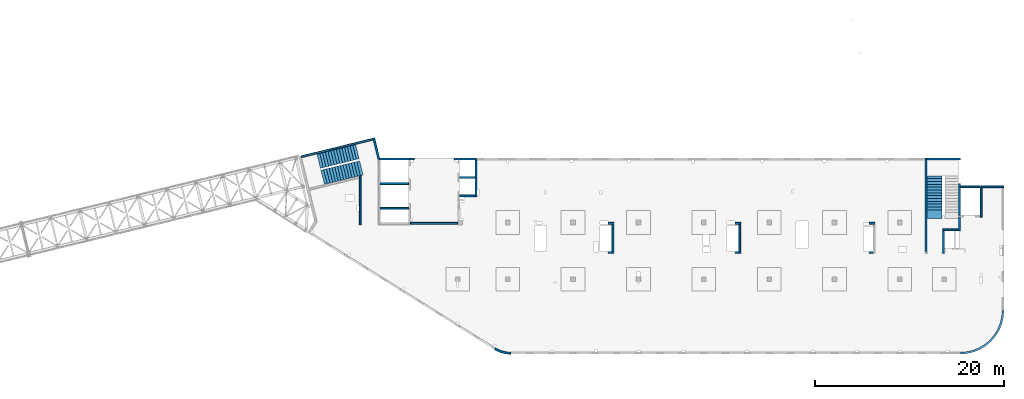
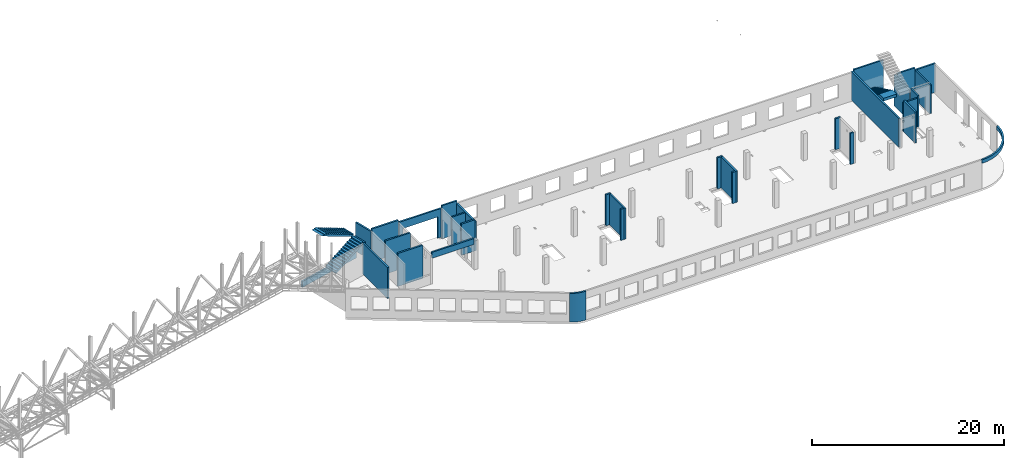
# One storey, part 21 of 92: 31 walls, 3 stairs, 1 opening.
"""IFC4 building model written with IfcOpenShell, lengths in millimetres."""

from ifc_helpers import new_model, entity, si_unit, converted_unit, derived_unit, direction, frame, origin, place, context, subcontext, project, spatial, indexed_curve, outline, extrude, polygons, material, type_object, element, save


model = new_model("IFC4")

# Units and contexts
model_context = context("Model", 3, precision=0.01, world=origin(), true_north=direction((6.12303176911189e-17, 1.0)))
plan_context = context("Plan", 3, precision=0.01, world=origin(), true_north=direction((6.12303176911189e-17, 1.0)))
body_context = subcontext(model_context, "Body", "Model", "MODEL_VIEW")
ifc_project = project(units=[si_unit("LENGTHUNIT", "METRE", prefix="MILLI"), si_unit("AREAUNIT", "SQUARE_METRE"), si_unit("VOLUMEUNIT", "CUBIC_METRE"), converted_unit("PLANEANGLEUNIT", "DEGREE", entity("IfcRatioMeasure", 0.0174532925199433), si_unit("PLANEANGLEUNIT", "RADIAN"), dimensions=[0, 0, 0, 0, 0, 0, 0]), si_unit("MASSUNIT", "GRAM", prefix="KILO"), derived_unit("MASSDENSITYUNIT", [(si_unit("MASSUNIT", "GRAM", prefix="KILO"), 1), (si_unit("LENGTHUNIT", "METRE"), -3)]), derived_unit("MOMENTOFINERTIAUNIT", [(si_unit("LENGTHUNIT", "METRE"), 4)]), si_unit("TIMEUNIT", "SECOND"), si_unit("FREQUENCYUNIT", "HERTZ"), si_unit("THERMODYNAMICTEMPERATUREUNIT", "DEGREE_CELSIUS"), derived_unit("THERMALTRANSMITTANCEUNIT", [(si_unit("MASSUNIT", "GRAM", prefix="KILO"), 1), (si_unit("THERMODYNAMICTEMPERATUREUNIT", "KELVIN"), -1), (si_unit("TIMEUNIT", "SECOND"), -3)]), derived_unit("VOLUMETRICFLOWRATEUNIT", [(si_unit("LENGTHUNIT", "METRE"), 3), (si_unit("TIMEUNIT", "SECOND"), -1)]), derived_unit("MASSFLOWRATEUNIT", [(si_unit("MASSUNIT", "GRAM", prefix="KILO"), 1), (si_unit("TIMEUNIT", "SECOND"), -1)]), derived_unit("ROTATIONALFREQUENCYUNIT", [(si_unit("TIMEUNIT", "SECOND"), -1)]), si_unit("ELECTRICCURRENTUNIT", "AMPERE"), si_unit("ELECTRICVOLTAGEUNIT", "VOLT"), si_unit("POWERUNIT", "WATT"), si_unit("FORCEUNIT", "NEWTON", prefix="KILO"), si_unit("ILLUMINANCEUNIT", "LUX"), si_unit("LUMINOUSFLUXUNIT", "LUMEN"), si_unit("LUMINOUSINTENSITYUNIT", "CANDELA"), derived_unit("USERDEFINED", [(si_unit("MASSUNIT", "GRAM", prefix="KILO"), -1), (si_unit("LENGTHUNIT", "METRE"), -2), (si_unit("TIMEUNIT", "SECOND"), 3), (si_unit("LUMINOUSFLUXUNIT", "LUMEN"), 1)]), derived_unit("LINEARVELOCITYUNIT", [(si_unit("LENGTHUNIT", "METRE"), 1), (si_unit("TIMEUNIT", "SECOND"), -1)]), si_unit("PRESSUREUNIT", "PASCAL"), derived_unit("USERDEFINED", [(si_unit("LENGTHUNIT", "METRE"), -2), (si_unit("MASSUNIT", "GRAM", prefix="KILO"), 1), (si_unit("TIMEUNIT", "SECOND"), -2)]), derived_unit("LINEARFORCEUNIT", [(si_unit("MASSUNIT", "GRAM", prefix="KILO"), 1), (si_unit("LENGTHUNIT", "METRE"), 1), (si_unit("TIMEUNIT", "SECOND"), -2), (si_unit("LENGTHUNIT", "METRE"), -1)]), derived_unit("PLANARFORCEUNIT", [(si_unit("MASSUNIT", "GRAM", prefix="KILO"), 1), (si_unit("LENGTHUNIT", "METRE"), 1), (si_unit("TIMEUNIT", "SECOND"), -2), (si_unit("LENGTHUNIT", "METRE"), -2)])], contexts=[model_context, plan_context])

# Site, building, storey
site_placement = place(None, origin())
site = spatial("IfcSite", under=ifc_project, at=site_placement, CompositionType="ELEMENT")
building_placement = place(site_placement, origin())
building = spatial("IfcBuilding", under=site, at=building_placement, CompositionType="ELEMENT")
storey_placement = place(building_placement, frame((0.0, 0.0, 15900.0)))
storey = spatial("IfcBuildingStorey", under=building, at=storey_placement, Name="05", CompositionType="ELEMENT", Elevation=15900.0)

# Walls
ifc_material_1 = material()
wall_type = type_object("IfcWallType", Name=":ADSK_ 25_200", PredefinedType="STANDARD")
wall_1_placement = place(storey_placement, frame((71070.0, 17470.0, -150.0)))
element("IfcWall", 1, at=wall_1_placement, inside=storey, type_object=wall_type, material=ifc_material_1, Name=":ADSK_ 25_200", ObjectType=":ADSK_ 25_200", PredefinedType="NOTDEFINED", context=body_context, shape_type="SweptSolid", body=[
    extrude(outline(indexed_curve([(2500.00000000001, -99.9999999999999), (2500.00000000001, 100.0), (99.9999999999943, 99.9999999999992), (99.9999999999949, -100.000000000001), (199.999999999998, -100.0), (2300.00000000001, -100.0), (2500.00000000001, -99.9999999999999)], self_intersect=False)), origin(), (0.0, 0.0, 1.0), 3650.0),
])
wall_2_placement = place(storey_placement, frame((71170.0, 17370.0, -150.0), z_axis=(0.0, 0.0, 1.0), x_axis=(0.0, -1.0, 0.0)))
element("IfcWall", 2, at=wall_2_placement, inside=storey, type_object=wall_type, material=ifc_material_1, Name=":ADSK_ 25_200", ObjectType=":ADSK_ 25_200", PredefinedType="NOTDEFINED", context=body_context, shape_type="SweptSolid", body=[
    extrude(outline(indexed_curve([(3100.0, 100.000000000003), (-2.79449581754433e-13, 100.000000000003), (2.79449581754433e-13, -100.000000000003), (3100.0, -100.000000000003), (3100.0, 100.000000000003)], self_intersect=False)), origin(), (0.0, 0.0, 1.0), 3650.0),
])
wall_3_placement = place(storey_placement, frame((68870.0, 14270.0, -150.0), z_axis=(0.0, 0.0, 1.0), x_axis=(0.0, -1.0, 0.0)))
element("IfcWall", 3, at=wall_3_placement, inside=storey, type_object=wall_type, material=ifc_material_1, Name=":ADSK_ 25_200", ObjectType=":ADSK_ 25_200", PredefinedType="NOTDEFINED", context=body_context, shape_type="SweptSolid", body=[
    extrude(outline(indexed_curve([(1439.99999999999, 100.000000000003), (0.0, 100.000000000003), (0.0, -100.000000000003), (1439.99999999999, -100.000000000003), (1439.99999999999, 100.000000000003)], self_intersect=False)), origin(), (0.0, 0.0, 1.0), 3950.0),
])
wall_4_placement = place(storey_placement, frame((68770.0, 12930.0, -150.0), z_axis=(0.0, 0.0, 1.0), x_axis=(-1.0, 0.0, 0.0)))
element("IfcWall", 4, at=wall_4_placement, inside=storey, type_object=wall_type, material=ifc_material_1, Name=":ADSK_ 25_200", ObjectType=":ADSK_ 25_200", PredefinedType="NOTDEFINED", context=body_context, shape_type="SweptSolid", body=[
    extrude(outline(indexed_curve([(1689.99999999997, 99.9999999999989), (-3.84449868389964e-13, 99.9999999999989), (3.84449868389964e-13, -99.9999999999989), (1689.99999999997, -99.9999999999989), (1689.99999999997, 99.9999999999989)], self_intersect=False)), origin(), (0.0, 0.0, 1.0), 3650.0),
])
wall_5_placement = place(storey_placement, frame((67180.0, 12830.0, -150.0), z_axis=(0.0, 0.0, 1.0), x_axis=(0.0, -1.0, 0.0)))
element("IfcWall", 5, at=wall_5_placement, inside=storey, type_object=wall_type, material=ifc_material_1, Name=":ADSK_ 25_200", ObjectType=":ADSK_ 25_200", PredefinedType="NOTDEFINED", context=body_context, shape_type="SweptSolid", body=[
    extrude(outline(indexed_curve([(2404.99999999995, 100.000000000003), (0.0, 100.000000000003), (0.0, -100.000000000003), (2404.99999999995, -100.000000000003), (2404.99999999995, 100.000000000003)], self_intersect=False)), origin(), (0.0, 0.0, 1.0), 3950.0),
])
wall_6_placement = place(storey_placement, frame((65330.0, 10625.0, -150.0), z_axis=(0.0, 0.0, 1.0), x_axis=(0.0, 1.0, 0.0)))
element("IfcWall", 6, at=wall_6_placement, inside=storey, type_object=wall_type, material=ifc_material_1, Name=":ADSK_ 25_200", ObjectType=":ADSK_ 25_200", PredefinedType="NOTDEFINED", context=body_context, shape_type="SweptSolid", body=[
    extrude(outline(indexed_curve([(9875.00063936713, 100.000000000003), (-1.71685740578866e-13, 100.000000000003), (1.71685740578866e-13, -100.000000000003), (9875.00063936713, -100.000000000004), (9875.00063936713, 100.000000000003)], self_intersect=False)), origin(), (0.0, 0.0, 1.0), 3650.0),
])
wall_7_placement = place(storey_placement, frame((68970.0, -100.0, 3050.0)))
element("IfcWall", 7, at=wall_7_placement, inside=storey, type_object=wall_type, material=ifc_material_1, Name=":ADSK_ 25_200", ObjectType=":ADSK_ 25_200", PredefinedType="NOTDEFINED", context=body_context, shape_type="SweptSolid", body=[
    extrude(outline(indexed_curve([(4399.99918212903, 4499.99918212888), (4345.82789081698, 3811.68766389508), (4184.64789385715, 3140.32465961517), (3920.42797770043, 2502.44135458057), (3559.67411357824, 1913.74455277455), (3111.26925889869, 1388.72992323025), (2586.25462935438, 940.325068550716), (1997.55782754836, 579.571204428538), (1359.67452251375, 315.351288271842), (688.311518233829, 154.171291312031), (3.46517481375486e-11, 100.0), (0.0, -100.0), (719.598411241839, -43.3663768070014), (1421.47792138871, 125.139985012801), (2088.35592749623, 401.369899590849), (2703.81167981284, 778.521669675706), (3252.69061513597, 1247.30856699292), (3721.47751245321, 1796.18750231603), (4098.6292825381, 2411.64325463263), (4374.85919711618, 3078.52126074015), (4543.365558936, 3780.40077088701), (4599.99918212903, 4499.99918212885), (4399.99918212903, 4499.99918212888)], self_intersect=False)), origin(), (0.0, 0.0, 1.0), 450.000000000002),
])
wall_8_placement = place(storey_placement, frame((19822.35, 371.16, -150.0)))
element("IfcWall", 8, at=wall_8_placement, inside=storey, type_object=wall_type, material=ifc_material_1, Name=":ADSK_ 25_200", ObjectType=":ADSK_ 25_200", PredefinedType="NOTDEFINED", context=body_context, shape_type="SweptSolid", body=[
    extrude(outline(indexed_curve([(1647.48298908956, -371.159642137684), (1479.53495854193, -366.732336838998), (1312.09852486252, -352.905454552832), (1145.69934172072, -329.72240370142), (980.859806418502, -297.255965670987), (818.09741986465, -255.608066320247), (657.923161920899, -204.909455992096), (500.839887220395, -145.319299033065), (347.340746494629, -77.024674109233), (197.907638365059, -0.239986887291593), (53.0096964598414, 84.7937030753815), (-53.0096964598197, -84.7937030753918), (101.553010904459, -175.499182842681), (260.953382356765, -257.405447245706), (424.69099282044, -330.255357933605), (592.251800794088, -393.820208274097), (763.109762144871, -447.900441360165), (936.728481583211, -492.326276503471), (1112.5628966341, -526.958242247616), (1290.06098881835, -551.687614227945), (1468.66551667174, -566.436756503237), (1647.81576516126, -571.159365287708), (1647.48298908956, -371.159642137684)], self_intersect=False)), origin(), (0.0, 0.0, 1.0), 3650.0),
])
wall_9_placement = place(storey_placement, frame((17825.0, 20300.0, -150.0), z_axis=(0.0, 0.0, 1.0), x_axis=(0.0, -1.0, 0.0)))
element("IfcWall", 9, at=wall_9_placement, inside=storey, type_object=wall_type, material=ifc_material_1, Name=":ADSK_ 25_200", ObjectType=":ADSK_ 25_200", PredefinedType="NOTDEFINED", context=body_context, shape_type="SweptSolid", body=[
    extrude(outline(indexed_curve([(3900.00063936684, 99.9999999999989), (-1.66594915657375e-13, 99.9999999999989), (1.66594915657375e-13, -99.9999999999989), (3900.00063936684, -99.9999999999989), (3900.00063936684, 99.9999999999989)], self_intersect=False)), origin(), (0.0, 0.0, 1.0), 3650.0),
])
wall_10_placement = place(storey_placement, frame((17725.0, 16500.0, -150.0), z_axis=(0.0, 0.0, 1.0), x_axis=(-1.0, 0.0, 0.0)))
element("IfcWall", 10, at=wall_10_placement, inside=storey, type_object=wall_type, material=ifc_material_1, Name=":ADSK_ 25_200", ObjectType=":ADSK_ 25_200", PredefinedType="NOTDEFINED", context=body_context, shape_type="SweptSolid", body=[
    extrude(outline(indexed_curve([(1624.99999999999, 99.9999999999982), (-3.56011111002209e-13, 99.9999999999989), (3.56011111002209e-13, -99.9999999999989), (1624.99999999999, -99.9999999999996), (1624.99999999999, 99.9999999999982)], self_intersect=False)), origin(), (0.0, 0.0, 1.0), 3950.0),
])
wall_11_placement = place(storey_placement, frame((5600.0, 13450.0, -150.0), z_axis=(0.0, 0.0, 1.0), x_axis=(0.0, 1.0, 0.0)))
element("IfcWall", 11, at=wall_11_placement, inside=storey, type_object=wall_type, material=ifc_material_1, Name=":ADSK_ 25_200", ObjectType=":ADSK_ 25_200", PredefinedType="NOTDEFINED", context=body_context, shape_type="SweptSolid", body=[
    extrude(outline(indexed_curve([(5191.05764338749, -100.0), (5142.30552742916, 99.9999999999995), (4936.44934265344, 100.0), (-1.37676332088153e-13, 100.0), (1.37676332088153e-13, -100.0), (5191.05764338749, -100.0)], self_intersect=False)), origin(), (0.0, 0.0, 1.0), 3950.0),
])

# Wall, opening
wall_12_placement = place(storey_placement, frame((10900.0, 20400.0, -150.0)))
wall_12 = element("IfcWall", 12, at=wall_12_placement, inside=storey, type_object=wall_type, material=ifc_material_1, Name=":ADSK_ 25_200", ObjectType=":ADSK_ 25_200", PredefinedType="NOTDEFINED", context=body_context, shape_type="Tessellation", body=[
    polygons([(5000.0, -100.000000000003, 3650.0), (-4.99784381508401e-13, -100.000000000003, 3650.0), (-4.99784381508401e-13, -100.000000000003, -2.16573425859679e-12), (399.999999999991, -99.9999999999989, -2.16573425859679e-12), (399.999999999993, -100.000000000003, 2699.99999999805), (4599.99999999999, -100.000000000003, 2699.99999999804), (4599.99999999999, -100.000000000003, -2.16573425859679e-12), (5000.0, -100.000000000003, -2.16573425859679e-12), (-1.16616415338434e-12, 99.9999999999989, 3650.0), (5000.0, 99.9999999999989, 3650.0), (5000.0, 99.9999999999989, 49.9999999999973), (5000.0, 99.9999999999989, -2.16573425859679e-12), (4599.99999999999, 99.9999999999989, -2.16573425859679e-12), (4599.99999999999, 99.9999999999989, 2699.99999999804), (399.999999999992, 100.000000000003, 2699.99999999805), (399.999999999992, 100.000000000003, -2.16573425859679e-12), (-1.16616415338434e-12, 99.9999999999989, -2.16573425859679e-12), (-1.16616415338434e-12, 99.9999999999989, 49.9999999999973)], [[[1, 2, 3, 4, 5, 6, 7, 8]], [[9, 10, 11, 12, 13, 14, 15, 16, 17, 18]], [[3, 17, 16, 4]], [[2, 1, 10, 9]], [[5, 15, 14, 6]], [[6, 14, 13, 7]], [[15, 5, 4, 16]], [[8, 12, 11, 10, 1]], [[17, 3, 2, 9, 18]], [[12, 8, 7, 13]]], closed=True),
])
opening_placement = place(wall_12_placement, frame((-10900.0, -20400.0, 150.0)))
element("IfcOpeningElement", 13, at=opening_placement, cuts=wall_12, Name=":ADSK_ 25_200", PredefinedType="OPENING", context=body_context, shape_type="SweptSolid", body=[
    extrude(outline(indexed_curve([(-2100.0, -1349.99999999902), (2100.0, -1349.99999999902), (2100.0, 1349.99999999902), (-2100.0, 1349.99999999902), (-2100.0, -1349.99999999902)], self_intersect=False)), frame((13400.0, 20200.0, 1200.0), z_axis=(0.0, 1.0, 0.0), x_axis=(1.0, 0.0, 0.0)), (0.0, 0.0, 1.0), 400.000000001945),
])

# Walls
wall_13_placement = place(storey_placement, frame((68870.0, 17780.0, -400.0), z_axis=(0.0, 0.0, 1.0), x_axis=(0.0, -1.0, 0.0)))
element("IfcWall", 14, at=wall_13_placement, inside=storey, type_object=wall_type, material=ifc_material_1, Name=":ADSK_ 25_200", ObjectType=":ADSK_ 25_200", PredefinedType="NOTDEFINED", context=body_context, shape_type="Tessellation", body=[
    polygons([(2.16573425859679e-12, -99.9999999999946, 0.0), (3310.0, -99.9999999999946, 0.0), (3310.0, -99.9999999999946, 299.999999999997), (3310.0, -99.9999999999946, 3900.0), (2.16573425859679e-12, -99.9999999999946, 3900.0), (3310.0, 100.000000000012, 0.0), (410.0, 100.000000000003, 0.0), (210.0, 100.000000000003, 0.0), (2.16573425859679e-12, 100.000000000012, 0.0), (2.16573425859679e-12, 100.000000000012, 3900.0), (3310.0, 100.000000000012, 3900.0)], [[[1, 2, 3, 4, 5]], [[6, 7, 8, 9, 10, 11]], [[2, 1, 9, 8, 7, 6]], [[9, 1, 5, 10]], [[2, 6, 11, 4, 3]], [[5, 4, 11, 10]]], closed=True),
])
wall_14_placement = place(storey_placement, frame((68970.0, 17470.0, -100.0)))
element("IfcWall", 15, at=wall_14_placement, inside=storey, type_object=wall_type, material=ifc_material_1, Name=":ADSK_ 25_200", ObjectType=":ADSK_ 25_200", PredefinedType="NOTDEFINED", context=body_context, shape_type="Tessellation", body=[
    polygons([(2099.99918212888, -100.000000000001, 2.16573425859679e-12), (2099.99918212888, -100.000000000001, 3600.0), (2099.99918212888, -100.000000000001, 3850.0), (2099.99918212888, -100.000000000001, 3900.0), (6.89939203009021e-12, -100.000000000001, 3900.0), (6.89939203009021e-12, -100.000000000001, 2.16573425859679e-12), (6.28061057235613e-12, 99.9999999999989, 3900.0), (2099.99918212888, 99.9999999999989, 3900.0), (2099.99918212888, 99.9999999999989, 3850.0), (2099.99918212888, 99.9999999999989, 3600.0), (2099.99918212888, 99.9999999999989, 2.16573425859679e-12), (6.28061057235613e-12, 99.9999999999989, 2.16573425859679e-12)], [[[1, 2, 3, 4, 5, 6]], [[7, 8, 9, 10, 11, 12]], [[5, 4, 8, 7]], [[5, 7, 12, 6]], [[1, 11, 10, 9, 8, 4, 3, 2]], [[1, 6, 12, 11]]], closed=True),
])
wall_15_placement = place(storey_placement, frame((65430.0, 20400.0, -400.0)))
element("IfcWall", 16, at=wall_15_placement, inside=storey, type_object=wall_type, material=ifc_material_1, Name=":ADSK_ 25_200", ObjectType=":ADSK_ 25_200", PredefinedType="NOTDEFINED", context=body_context, shape_type="SweptSolid", body=[
    extrude(outline(indexed_curve([(3539.99999999995, 99.9999999999989), (-3.67073603151997e-13, 99.9999999999989), (3.67073603151997e-13, -99.9999999999989), (3539.99999999995, -99.9999999999989), (3539.99999999995, 99.9999999999989)], self_intersect=False)), origin(), (0.0, 0.0, 1.0), 4150.0),
])
wall_16_placement = place(storey_placement, frame((16000.0, 20400.0, -400.0)))
element("IfcWall", 17, at=wall_16_placement, inside=storey, type_object=wall_type, material=ifc_material_1, Name=":ADSK_ 25_200", ObjectType=":ADSK_ 25_200", PredefinedType="NOTDEFINED", context=body_context, shape_type="SweptSolid", body=[
    extrude(outline(indexed_curve([(1824.99999999999, -100.000000000003), (1824.99999999999, 99.9999999999995), (1724.99999999999, 99.9999999999992), (99.9999999999987, 99.9999999999992), (-2.66551908750372e-13, 99.9999999999989), (2.66551908750383e-13, -100.000000000003), (1724.99999999999, -100.000000000003), (1824.99999999999, -100.000000000003)], self_intersect=False)), origin(), (0.0, 0.0, 1.0), 4200.0),
])
wall_17_placement = place(storey_placement, frame((16100.0, 18450.0, -400.0)))
element("IfcWall", 18, at=wall_17_placement, inside=storey, type_object=wall_type, material=ifc_material_1, Name=":ADSK_ 25_200", ObjectType=":ADSK_ 25_200", PredefinedType="NOTDEFINED", context=body_context, shape_type="SweptSolid", body=[
    extrude(outline(indexed_curve([(1624.99999999999, 99.9999999999989), (-2.66551908750371e-13, 99.9999999999989), (2.66551908750371e-13, -99.9999999999989), (1624.99999999999, -99.9999999999989), (1624.99999999999, 99.9999999999989)], self_intersect=False)), origin(), (0.0, 0.0, 1.0), 3900.0),
])
wall_18_placement = place(storey_placement, frame((7600.0, 20400.0, -400.0)))
element("IfcWall", 19, at=wall_18_placement, inside=storey, type_object=wall_type, material=ifc_material_1, Name=":ADSK_ 25_200", ObjectType=":ADSK_ 25_200", PredefinedType="NOTDEFINED", context=body_context, shape_type="SweptSolid", body=[
    extrude(outline(indexed_curve([(3200.0, -100.000000000003), (3200.0, 99.9999999999995), (3100.0, 99.9999999999992), (7.9410256148549e-13, 99.9999999999989), (2.88764567812915e-13, -100.000000000003), (3200.0, -100.000000000003)], self_intersect=False)), origin(), (0.0, 0.0, 1.0), 4200.0),
])
for number, where, name in (
    (20, (7700.0, 17800.0, -400.0), ":ADSK_ 25_200"),
    (21, (7700.0, 15200.0, -400.0), ":ADSK_ 25_200"),
):
    element("IfcWall", number, at=place(storey_placement, frame(where)), inside=storey, type_object=wall_type, material=ifc_material_1, Name=name, ObjectType=":ADSK_ 25_200", PredefinedType="NOTDEFINED", context=body_context, shape_type="SweptSolid", body=[
        extrude(outline(indexed_curve([(3000.0, 99.9999999999989), (-2.88764567812902e-13, 99.9999999999989), (2.88764567812902e-13, -99.9999999999989), (3000.0, -99.9999999999989), (3000.0, 99.9999999999989)], self_intersect=False)), origin(), (0.0, 0.0, 1.0), 4200.0),
    ])
wall_19_placement = place(storey_placement, frame((59330.0, 13600.0, -150.0)))
element("IfcWall", 22, at=wall_19_placement, inside=storey, type_object=wall_type, material=ifc_material_1, Name=":ADSK_ 25_200", ObjectType=":ADSK_ 25_200", PredefinedType="NOTDEFINED", context=body_context, shape_type="SweptSolid", body=[
    extrude(outline(indexed_curve([(599.999999999993, 99.9999999999989), (-3.60955709766131e-13, 99.9999999999989), (3.60955709766131e-13, -99.9999999999989), (599.999999999994, -99.9999999999989), (599.999999999993, 99.9999999999989)], self_intersect=False)), origin(), (0.0, 0.0, 1.0), 3950.0),
])
wall_20_placement = place(storey_placement, frame((59730.0, 10525.0, -150.0), z_axis=(0.0, 0.0, 1.0), x_axis=(-1.0, 0.0, 0.0)))
element("IfcWall", 23, at=wall_20_placement, inside=storey, type_object=wall_type, material=ifc_material_1, Name=":ADSK_ 25_200", ObjectType=":ADSK_ 25_200", PredefinedType="NOTDEFINED", context=body_context, shape_type="SweptSolid", body=[
    extrude(outline(indexed_curve([(399.999999999987, 99.9999999999982), (-3.60955709766136e-13, 99.9999999999989), (3.60955709766136e-13, -99.9999999999989), (399.999999999987, -99.9999999999996), (399.999999999987, 99.9999999999982)], self_intersect=False)), origin(), (0.0, 0.0, 1.0), 3950.0),
])
wall_21_placement = place(storey_placement, frame((45170.0, 13600.0, -150.0)))
element("IfcWall", 24, at=wall_21_placement, inside=storey, type_object=wall_type, material=ifc_material_1, Name=":ADSK_ 25_200", ObjectType=":ADSK_ 25_200", PredefinedType="NOTDEFINED", context=body_context, shape_type="SweptSolid", body=[
    extrude(outline(indexed_curve([(599.999999999993, 99.9999999999989), (-3.60955709766131e-13, 99.9999999999989), (3.60955709766131e-13, -99.9999999999989), (599.999999999994, -99.9999999999989), (599.999999999993, 99.9999999999989)], self_intersect=False)), origin(), (0.0, 0.0, 1.0), 3950.0),
])
wall_22_placement = place(storey_placement, frame((45670.0, 13500.0, -150.0), z_axis=(0.0, 0.0, 1.0), x_axis=(0.0, -1.0, 0.0)))
element("IfcWall", 25, at=wall_22_placement, inside=storey, type_object=wall_type, material=ifc_material_1, Name=":ADSK_ 25_200", ObjectType=":ADSK_ 25_200", PredefinedType="NOTDEFINED", context=body_context, shape_type="SweptSolid", body=[
    extrude(outline(indexed_curve([(3074.99985044015, 100.000000000003), (-2.64517173435081e-13, 100.000000000003), (2.64517173435081e-13, -100.000000000003), (3074.99985044015, -100.000000000004), (3074.99985044015, 100.000000000003)], self_intersect=False)), origin(), (0.0, 0.0, 1.0), 3950.0),
])
wall_23_placement = place(storey_placement, frame((45570.0, 10525.0, -150.0), z_axis=(0.0, 0.0, 1.0), x_axis=(-1.0, 0.0, 0.0)))
element("IfcWall", 26, at=wall_23_placement, inside=storey, type_object=wall_type, material=ifc_material_1, Name=":ADSK_ 25_200", ObjectType=":ADSK_ 25_200", PredefinedType="NOTDEFINED", context=body_context, shape_type="SweptSolid", body=[
    extrude(outline(indexed_curve([(399.999999999995, 99.9999999999982), (-3.60955709766131e-13, 99.9999999999989), (3.60955709766131e-13, -99.9999999999989), (399.999999999996, -99.9999999999996), (399.999999999995, 99.9999999999982)], self_intersect=False)), origin(), (0.0, 0.0, 1.0), 3950.0),
])
wall_24_placement = place(storey_placement, frame((31770.0, 13600.0, -150.0)))
element("IfcWall", 27, at=wall_24_placement, inside=storey, type_object=wall_type, material=ifc_material_1, Name=":ADSK_ 25_200", ObjectType=":ADSK_ 25_200", PredefinedType="NOTDEFINED", context=body_context, shape_type="SweptSolid", body=[
    extrude(outline(indexed_curve([(600.000000000002, 99.9999999999989), (-3.60955709766126e-13, 99.9999999999989), (3.60955709766126e-13, -99.9999999999989), (600.000000000003, -99.9999999999989), (600.000000000002, 99.9999999999989)], self_intersect=False)), origin(), (0.0, 0.0, 1.0), 3950.0),
])
wall_25_placement = place(storey_placement, frame((32270.0, 13500.0, -150.0), z_axis=(0.0, 0.0, 1.0), x_axis=(0.0, -1.0, 0.0)))
element("IfcWall", 28, at=wall_25_placement, inside=storey, type_object=wall_type, material=ifc_material_1, Name=":ADSK_ 25_200", ObjectType=":ADSK_ 25_200", PredefinedType="NOTDEFINED", context=body_context, shape_type="SweptSolid", body=[
    extrude(outline(indexed_curve([(3074.99985044025, 99.9999999999987), (-1.32258586717531e-13, 99.9999999999989), (1.32258586717531e-13, -99.9999999999989), (3074.99985044025, -99.9999999999992), (3074.99985044025, 99.9999999999987)], self_intersect=False)), origin(), (0.0, 0.0, 1.0), 3950.0),
])
wall_26_placement = place(storey_placement, frame((32170.0, 10525.0, -150.0), z_axis=(0.0, 0.0, 1.0), x_axis=(-1.0, 0.0, 0.0)))
element("IfcWall", 29, at=wall_26_placement, inside=storey, type_object=wall_type, material=ifc_material_1, Name=":ADSK_ 25_200", ObjectType=":ADSK_ 25_200", PredefinedType="NOTDEFINED", context=body_context, shape_type="SweptSolid", body=[
    extrude(outline(indexed_curve([(399.999999999995, 99.9999999999982), (-3.60955709766131e-13, 99.9999999999989), (3.60955709766131e-13, -99.9999999999989), (399.999999999996, -99.9999999999996), (399.999999999995, 99.9999999999982)], self_intersect=False)), origin(), (0.0, 0.0, 1.0), 3950.0),
])
wall_27_placement = place(storey_placement, frame((10900.0, 13600.0, 3050.0)))
element("IfcWall", 30, at=wall_27_placement, inside=storey, type_object=wall_type, material=ifc_material_1, Name=":ADSK_ 25_200", ObjectType=":ADSK_ 25_200", PredefinedType="NOTDEFINED", context=body_context, shape_type="SweptSolid", body=[
    extrude(outline(indexed_curve([(4999.99925537109, 99.9999999999989), (-3.03202841358267e-13, 99.9999999999989), (3.03202841358267e-13, -99.9999999999989), (4999.99925537109, -99.9999999999989), (4999.99925537109, 99.9999999999989)], self_intersect=False)), origin(), (0.0, 0.0, 1.0), 749.999999999998),
])
wall_28_placement = place(storey_placement, frame((7033.44, 22609.75, -150.0), z_axis=(0.0, 0.0, 1.0), x_axis=(0.236826092990327, -0.971552058141475, 0.0)))
element("IfcWall", 31, at=wall_28_placement, inside=storey, type_object=wall_type, material=ifc_material_1, Name=":ADSK_ 25_200", ObjectType=":ADSK_ 25_200", PredefinedType="NOTDEFINED", context=body_context, shape_type="SweptSolid", body=[
    extrude(outline(indexed_curve([(2380.28371765147, -100.0), (2354.53748529952, -93.7240834744374), (2160.22707367122, -46.3588648763715), (2195.90359543113, 99.9999999999993), (-1.90347737571983e-13, 99.9999999999987), (-6.76791955811495e-14, -99.9999999999997), (199.999999999995, -99.9999999999999), (2380.28371765147, -100.0)], self_intersect=False)), origin(), (0.0, 0.0, 1.0), 3650.0),
])
wall_29_placement = place(storey_placement, frame((-618.13, 20641.67, -900.0), z_axis=(0.0, 0.0, 1.0), x_axis=(0.971552058141473, 0.236826092990338, 0.0)))
element("IfcWall", 32, at=wall_29_placement, inside=storey, type_object=wall_type, material=ifc_material_1, Name=":ADSK_ 25_200", ObjectType=":ADSK_ 25_200", PredefinedType="NOTDEFINED", context=body_context, shape_type="SweptSolid", body=[
    extrude(outline(indexed_curve([(7799.9920696628, 100.000000000001), (-5.4989346409684e-14, 100.0), (5.4989346409684e-14, -100.0), (7799.9920696628, -99.9999999999997), (7799.9920696628, 100.000000000001)], self_intersect=False)), origin(), (0.0, 0.0, 1.0), 750.000000000003),
])

# Stairs
ifc_material_2 = material()
stair_type_1 = type_object("IfcStairType", Name="26: 22", PredefinedType="HALF_TURN_STAIR")
placement = place(storey_placement, origin())
element("IfcStair", 33, at=placement, inside=storey, type_object=stair_type_1, material=ifc_material_2, Name="26: 22", ObjectType="26: 22", PredefinedType="HALF_TURN_STAIR", context=body_context, shape_type="SweptSolid", body=[
    extrude(outline(indexed_curve([(-1981.81423970003, -851.999999999993), (-1981.81423970003, -1201.99999999999), (-1934.60064420008, -1202.0), (1625.39935579994, 578.000000000007), (2518.18576030048, 578.000000000009), (2518.18576030048, 948.000000000005), (1618.18576029998, 948.000000000005), (1618.18576029998, 798.000000000009), (1318.18576029998, 798.000000000009), (1318.18576029998, 648.000000000009), (1018.18576029998, 648.000000000009), (1018.18576029998, 498.000000000008), (718.185760299978, 498.000000000008), (718.185760299978, 348.000000000008), (418.185760299977, 348.000000000008), (418.185760299977, 198.000000000007), (118.185760299976, 198.000000000007), (118.185760299976, 48.0000000000086), (-181.814239700026, 48.0000000000086), (-181.814239700026, -101.999999999992), (-481.814239700027, -101.999999999992), (-481.814239700027, -251.999999999993), (-781.814239700028, -251.999999999993), (-781.814239700028, -401.999999999991), (-1081.81423970003, -401.999999999991), (-1081.81423970003, -551.999999999991), (-1381.81423970003, -551.999999999991), (-1381.81423970003, -701.999999999992), (-1681.81423970003, -701.999999999992), (-1681.81423970003, -851.999999999993), (-1981.81423970003, -851.999999999993)], self_intersect=False)), frame((65450.0, 16648.18, 2922.0), z_axis=(-1.0, 0.0, 0.0), x_axis=(0.0, -1.0, 0.0)), (0.0, 0.0, -1.0), 1550.0),
])
stair_type_2 = type_object("IfcStairType", Name="33: 3", PredefinedType="HALF_TURN_STAIR")
element("IfcStair", 34, at=placement, inside=storey, type_object=stair_type_2, material=ifc_material_2, Name="33: 3", ObjectType="33: 3", PredefinedType="HALF_TURN_STAIR", context=body_context, shape_type="SweptSolid", body=[
    extrude(outline(indexed_curve([(948.749999999984, -2110.21875405692), (1318.74999999998, -2110.21875405692), (1318.74999999999, -2103.9509192873), (-951.250000000018, 2436.0490807128), (-951.250000000018, 2088.83548521281), (-1001.25000000001, 2088.83548521281), (-1001.25000000001, 1788.83548521281), (-851.250000000006, 1788.83548521281), (-851.250000000006, 1488.83548521281), (-701.250000000005, 1488.83548521281), (-701.250000000005, 1188.8354852128), (-551.250000000005, 1188.8354852128), (-551.250000000005, 888.835485212796), (-401.250000000008, 888.835485212795), (-401.250000000008, 588.835485212792), (-251.250000000008, 588.835485212791), (-251.250000000008, 288.835485212788), (-101.250000000012, 288.835485212787), (-101.250000000012, -11.1645147872136), (48.7499999999889, -11.1645147872147), (48.7499999999889, -311.164514787218), (198.749999999989, -311.16451478722), (198.749999999989, -611.164514787222), (348.749999999986, -611.164514787223), (348.749999999986, -911.164514787227), (498.749999999986, -911.164514787228), (498.749999999986, -1211.16451478723), (648.749999999982, -1211.16451478723), (648.749999999982, -1511.16451478723), (798.749999999983, -1511.16451478723), (798.749999999983, -1810.69163442208), (948.749999999984, -1810.69163442208), (948.749999999984, -2110.21875405692)], self_intersect=False)), frame((3429.28, 19909.37, 4818.75), z_axis=(-0.236826092990677, 0.97155205814139, 0.0), x_axis=(0.0, 0.0, -1.0)), (0.0, 0.0, 1.0), 1550.00000000006),
])
stair_type_3 = type_object("IfcStairType", Name="38: 34", PredefinedType="HALF_TURN_STAIR")
element("IfcStair", 35, at=placement, inside=storey, type_object=stair_type_3, material=ifc_material_2, Name="38: 34", ObjectType="38: 34", PredefinedType="HALF_TURN_STAIR", context=body_context, shape_type="SweptSolid", body=[
    extrude(outline(indexed_curve([(-2082.95035407268, -903.75), (-2082.95035407268, -1253.75), (-2035.73675857273, -1253.75), (1524.26324142725, 526.249999999975), (2117.0417155901, 526.249999999973), (2117.0417155901, 776.249999999969), (1817.04964592736, 776.249999999971), (1817.04964592736, 896.250000000004), (1517.04964592735, 896.250000000006), (1517.04964592736, 746.250000000006), (1217.04964592735, 746.250000000008), (1217.04964592735, 596.250000000005), (917.049645927346, 596.250000000005), (917.049645927346, 446.250000000005), (617.049645927341, 446.250000000005), (617.049645927341, 296.250000000004), (317.049645927337, 296.250000000004), (317.049645927336, 146.250000000003), (17.0496459273316, 146.250000000003), (17.0496459273305, -3.74999999999711), (-282.950354072672, -3.74999999999711), (-282.950354072672, -153.749999999998), (-582.950354072676, -153.749999999998), (-582.950354072676, -303.749999999998), (-882.950354072679, -303.749999999998), (-882.950354072679, -453.749999999999), (-1182.95035407268, -453.749999999999), (-1182.95035407268, -603.749999999999), (-1482.95035407268, -603.749999999999), (-1482.95035407268, -753.75), (-1782.95035407268, -753.75), (-1782.95035407268, -903.75), (-2082.95035407268, -903.75)], self_intersect=False)), frame((3838.0, 18207.76, 2973.75), z_axis=(0.236826092990333, -0.971552058141474, 0.0), x_axis=(0.971552058141474, 0.236826092990333, 0.0)), (0.0, 0.0, -1.0), 1550.0),
])

save(model, "model.ifc")
